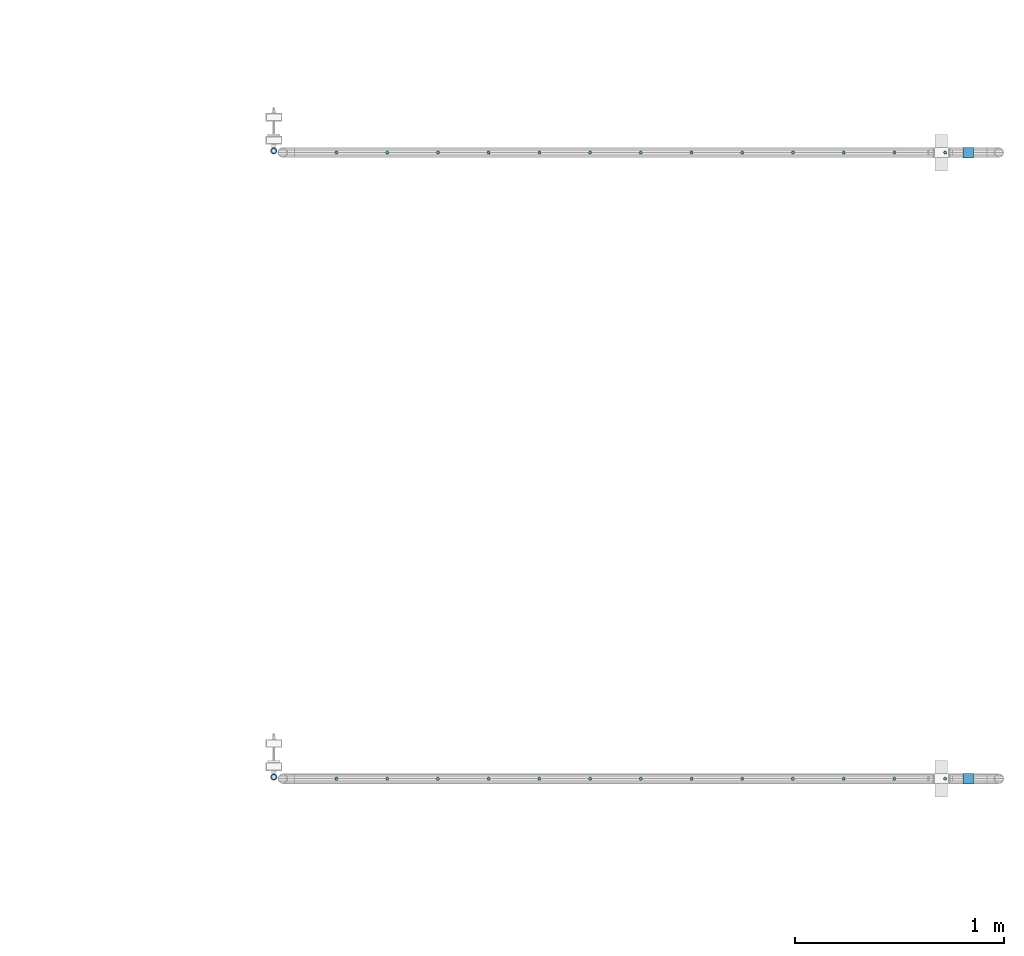
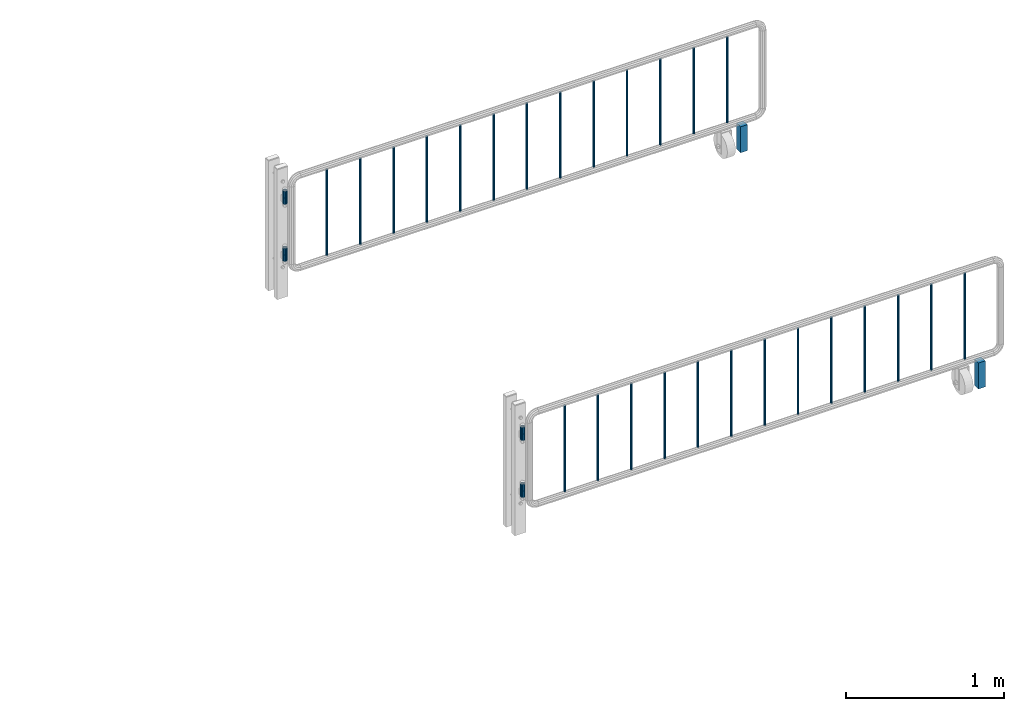
# One storey, part 89 of 208: 36 columns.
"""IFC2X3 building model written with IfcOpenShell, lengths in millimetres."""

from ifc_helpers import new_model, si_unit, frame, origin_with_axes, place, context, subcontext, project, spatial, faceted_brep, material, type_object, element, save


model = new_model("IFC2X3")

# Units and contexts
model_context = context("Model", 3, precision=1e-05, world=origin_with_axes())
body_context = subcontext(model_context, "Body", "Model", "MODEL_VIEW")
ifc_project = project(units=[si_unit("LENGTHUNIT", "METRE", prefix="MILLI"), si_unit("AREAUNIT", "SQUARE_METRE"), si_unit("VOLUMEUNIT", "CUBIC_METRE"), si_unit("MASSUNIT", "GRAM", prefix="KILO"), si_unit("TIMEUNIT", "SECOND"), si_unit("PLANEANGLEUNIT", "RADIAN"), si_unit("SOLIDANGLEUNIT", "STERADIAN"), si_unit("THERMODYNAMICTEMPERATUREUNIT", "DEGREE_CELSIUS"), si_unit("LUMINOUSINTENSITYUNIT", "LUMEN")], contexts=[model_context])

# Site, building, storey
site_placement = place(None, origin_with_axes())
site = spatial("IfcSite", under=ifc_project, at=site_placement, CompositionType="ELEMENT")
building_placement = place(site_placement, origin_with_axes())
building = spatial("IfcBuilding", under=site, at=building_placement, Name="Standard", CompositionType="ELEMENT")
storey_placement = place(building_placement, origin_with_axes())
storey = spatial("IfcBuildingStorey", under=building, at=storey_placement, Name="Undefined", CompositionType="ELEMENT", Elevation=0.0)

# Columns
ifc_material_1 = material(Name="STEEL/S355")
column_type_1 = type_object("IfcColumnType", PredefinedType="NOTDEFINED")
for number, where, z_axis, x_axis in (
    (1, (-12267.9037320793, 2941.85337247848, 0.500000000007276), (-1.0, 0.0, 0.0), (0.0, 0.0, 1.0)),
    (2, (-12267.9037320793, 5941.85337247848, 0.500000000007276), (-1.0, 0.0, 0.0), (0.0, 0.0, 1.0)),
):
    element("IfcColumn", number, at=place(storey_placement, frame(where, z_axis=z_axis, x_axis=x_axis)), inside=storey, type_object=column_type_1, material=ifc_material_1, context=body_context, shape_type="Brep", body=[
        faceted_brep([(0.0, 25.0, -25.0), (0.0, 25.0, 25.0), (200.0, 25.0, 25.0), (200.0, 25.0, -25.0), (0.0, -25.0, 25.0), (200.0, -25.0, 25.0), (0.0, -25.0, -25.0), (200.0, -25.0, -25.0)], [[[0, 1, 2, 3]], [[1, 4, 5, 2]], [[4, 6, 7, 5]], [[6, 0, 3, 7]], [[5, 7, 3, 2]], [[6, 4, 1, 0]]]),
    ])
ifc_material_2 = material()
column_type_2 = type_object("IfcColumnType", PredefinedType="NOTDEFINED")
column_1_placement = place(storey_placement, frame((-15594.2539762199, 2950.0039999962, 310.000000000008), z_axis=(-1.0, 0.0, 0.0), x_axis=(0.0, 0.0, 1.0)))
element("IfcColumn", 3, at=column_1_placement, inside=storey, type_object=column_type_2, material=ifc_material_2, context=body_context, shape_type="Brep", body=[
    faceted_brep([(0.0, -10.0, 0.0), (0.0, -8.66025403784442, 5.0), (50.0, -8.66025403784442, 5.0), (50.0, -10.0, 0.0), (0.0, -5.0, 8.66025403784442), (50.0, -5.0, 8.66025403784442), (0.0, 0.0, 10.0), (50.0, 0.0, 10.0), (0.0, 5.0, 8.66025403784442), (50.0, 5.0, 8.66025403784442), (0.0, 8.66025403784442, 5.0), (50.0, 8.66025403784442, 5.0), (0.0, 10.0, 0.0), (50.0, 10.0, 0.0), (0.0, 8.66025403784442, -5.0), (50.0, 8.66025403784442, -5.0), (0.0, 5.0, -8.66025403784442), (50.0, 5.0, -8.66025403784442), (0.0, 0.0, -10.0), (50.0, 0.0, -10.0), (0.0, -5.0, -8.66025403784442), (50.0, -5.0, -8.66025403784442), (0.0, -8.66025403784442, -5.0), (50.0, -8.66025403784442, -5.0), (0.0, -16.0, 0.0), (0.0, -13.8564064605512, -8.0), (50.0, -13.8564064605512, -8.0), (50.0, -16.0, 0.0), (0.0, -8.0, -13.8564064605507), (50.0, -8.0, -13.8564064605507), (0.0, 0.0, -16.0), (50.0, 0.0, -16.0), (0.0, 8.0, -13.8564064605507), (50.0, 8.0, -13.8564064605507), (0.0, 13.8564064605512, -8.0), (50.0, 13.8564064605512, -8.0), (0.0, 16.0, 0.0), (50.0, 16.0, 0.0), (0.0, 13.8564064605512, 8.0), (50.0, 13.8564064605512, 8.0), (0.0, 8.0, 13.8564064605507), (50.0, 8.0, 13.8564064605507), (0.0, 0.0, 16.0), (50.0, 0.0, 16.0), (0.0, -8.0, 13.8564064605507), (50.0, -8.0, 13.8564064605507), (0.0, -13.8564064605512, 8.0), (50.0, -13.8564064605512, 8.0)], [[[0, 1, 2, 3]], [[1, 4, 5, 2]], [[4, 6, 7, 5]], [[6, 8, 9, 7]], [[8, 10, 11, 9]], [[10, 12, 13, 11]], [[12, 14, 15, 13]], [[14, 16, 17, 15]], [[16, 18, 19, 17]], [[18, 20, 21, 19]], [[20, 22, 23, 21]], [[22, 0, 3, 23]], [[24, 25, 26, 27]], [[25, 28, 29, 26]], [[28, 30, 31, 29]], [[30, 32, 33, 31]], [[32, 34, 35, 33]], [[34, 36, 37, 35]], [[36, 38, 39, 37]], [[38, 40, 41, 39]], [[40, 42, 43, 41]], [[42, 44, 45, 43]], [[44, 46, 47, 45]], [[46, 24, 27, 47]], [[29, 31, 33, 35, 37, 39, 41, 43, 45, 47, 27, 26], [5, 7, 9, 11, 13, 15, 17, 19, 21, 23, 3, 2]], [[46, 44, 42, 40, 38, 36, 34, 32, 30, 28, 25, 24], [22, 20, 18, 16, 14, 12, 10, 8, 6, 4, 1, 0]]]),
])
column_2_placement = place(storey_placement, frame((-15594.2539762199, 2950.0039999962, 360.000000000008), z_axis=(-1.0, 0.0, 0.0), x_axis=(0.0, 0.0, 1.0)))
element("IfcColumn", 4, at=column_2_placement, inside=storey, type_object=column_type_2, material=ifc_material_2, context=body_context, shape_type="Brep", body=[
    faceted_brep([(0.0, -10.0, 0.0), (0.0, -8.66025403784442, 5.0), (50.0, -8.66025403784442, 5.0), (50.0, -10.0, 0.0), (0.0, -5.0, 8.66025403784442), (50.0, -5.0, 8.66025403784442), (0.0, 0.0, 10.0), (50.0, 0.0, 10.0), (0.0, 5.0, 8.66025403784442), (50.0, 5.0, 8.66025403784442), (0.0, 8.66025403784442, 5.0), (50.0, 8.66025403784442, 5.0), (0.0, 10.0, 0.0), (50.0, 10.0, 0.0), (0.0, 8.66025403784442, -5.0), (50.0, 8.66025403784442, -5.0), (0.0, 5.0, -8.66025403784442), (50.0, 5.0, -8.66025403784442), (0.0, 0.0, -10.0), (50.0, 0.0, -10.0), (0.0, -5.0, -8.66025403784442), (50.0, -5.0, -8.66025403784442), (0.0, -8.66025403784442, -5.0), (50.0, -8.66025403784442, -5.0), (0.0, -16.0, 0.0), (0.0, -13.8564064605512, -8.0), (50.0, -13.8564064605512, -8.0), (50.0, -16.0, 0.0), (0.0, -8.0, -13.8564064605507), (50.0, -8.0, -13.8564064605507), (0.0, 0.0, -16.0), (50.0, 0.0, -16.0), (0.0, 8.0, -13.8564064605507), (50.0, 8.0, -13.8564064605507), (0.0, 13.8564064605512, -8.0), (50.0, 13.8564064605512, -8.0), (0.0, 16.0, 0.0), (50.0, 16.0, 0.0), (0.0, 13.8564064605512, 8.0), (50.0, 13.8564064605512, 8.0), (0.0, 8.0, 13.8564064605507), (50.0, 8.0, 13.8564064605507), (0.0, 0.0, 16.0), (50.0, 0.0, 16.0), (0.0, -8.0, 13.8564064605507), (50.0, -8.0, 13.8564064605507), (0.0, -13.8564064605512, 8.0), (50.0, -13.8564064605512, 8.0)], [[[0, 1, 2, 3]], [[1, 4, 5, 2]], [[4, 6, 7, 5]], [[6, 8, 9, 7]], [[8, 10, 11, 9]], [[10, 12, 13, 11]], [[12, 14, 15, 13]], [[14, 16, 17, 15]], [[16, 18, 19, 17]], [[18, 20, 21, 19]], [[20, 22, 23, 21]], [[22, 0, 3, 23]], [[24, 25, 26, 27]], [[25, 28, 29, 26]], [[28, 30, 31, 29]], [[30, 32, 33, 31]], [[32, 34, 35, 33]], [[34, 36, 37, 35]], [[36, 38, 39, 37]], [[38, 40, 41, 39]], [[40, 42, 43, 41]], [[42, 44, 45, 43]], [[44, 46, 47, 45]], [[46, 24, 27, 47]], [[29, 31, 33, 35, 37, 39, 41, 43, 45, 47, 27, 26], [5, 7, 9, 11, 13, 15, 17, 19, 21, 23, 3, 2]], [[46, 44, 42, 40, 38, 36, 34, 32, 30, 28, 25, 24], [22, 20, 18, 16, 14, 12, 10, 8, 6, 4, 1, 0]]]),
])
column_3_placement = place(storey_placement, frame((-15594.2539762199, 2950.0039999962, 750.000000000008), z_axis=(-1.0, 0.0, 0.0), x_axis=(0.0, 0.0, 1.0)))
element("IfcColumn", 5, at=column_3_placement, inside=storey, type_object=column_type_2, material=ifc_material_2, context=body_context, shape_type="Brep", body=[
    faceted_brep([(0.0, -10.0, 0.0), (0.0, -8.66025403784442, 5.0), (50.0, -8.66025403784442, 5.0), (50.0, -10.0, 0.0), (0.0, -5.0, 8.66025403784442), (50.0, -5.0, 8.66025403784442), (0.0, 0.0, 10.0), (50.0, 0.0, 10.0), (0.0, 5.0, 8.66025403784442), (50.0, 5.0, 8.66025403784442), (0.0, 8.66025403784442, 5.0), (50.0, 8.66025403784442, 5.0), (0.0, 10.0, 0.0), (50.0, 10.0, 0.0), (0.0, 8.66025403784442, -5.0), (50.0, 8.66025403784442, -5.0), (0.0, 5.0, -8.66025403784442), (50.0, 5.0, -8.66025403784442), (0.0, 0.0, -10.0), (50.0, 0.0, -10.0), (0.0, -5.0, -8.66025403784442), (50.0, -5.0, -8.66025403784442), (0.0, -8.66025403784442, -5.0), (50.0, -8.66025403784442, -5.0), (0.0, -16.0, 0.0), (0.0, -13.8564064605512, -8.0), (50.0, -13.8564064605512, -8.0), (50.0, -16.0, 0.0), (0.0, -8.0, -13.8564064605507), (50.0, -8.0, -13.8564064605507), (0.0, 0.0, -16.0), (50.0, 0.0, -16.0), (0.0, 8.0, -13.8564064605507), (50.0, 8.0, -13.8564064605507), (0.0, 13.8564064605512, -8.0), (50.0, 13.8564064605512, -8.0), (0.0, 16.0, 0.0), (50.0, 16.0, 0.0), (0.0, 13.8564064605512, 8.0), (50.0, 13.8564064605512, 8.0), (0.0, 8.0, 13.8564064605507), (50.0, 8.0, 13.8564064605507), (0.0, 0.0, 16.0), (50.0, 0.0, 16.0), (0.0, -8.0, 13.8564064605507), (50.0, -8.0, 13.8564064605507), (0.0, -13.8564064605512, 8.0), (50.0, -13.8564064605512, 8.0)], [[[0, 1, 2, 3]], [[1, 4, 5, 2]], [[4, 6, 7, 5]], [[6, 8, 9, 7]], [[8, 10, 11, 9]], [[10, 12, 13, 11]], [[12, 14, 15, 13]], [[14, 16, 17, 15]], [[16, 18, 19, 17]], [[18, 20, 21, 19]], [[20, 22, 23, 21]], [[22, 0, 3, 23]], [[24, 25, 26, 27]], [[25, 28, 29, 26]], [[28, 30, 31, 29]], [[30, 32, 33, 31]], [[32, 34, 35, 33]], [[34, 36, 37, 35]], [[36, 38, 39, 37]], [[38, 40, 41, 39]], [[40, 42, 43, 41]], [[42, 44, 45, 43]], [[44, 46, 47, 45]], [[46, 24, 27, 47]], [[29, 31, 33, 35, 37, 39, 41, 43, 45, 47, 27, 26], [5, 7, 9, 11, 13, 15, 17, 19, 21, 23, 3, 2]], [[46, 44, 42, 40, 38, 36, 34, 32, 30, 28, 25, 24], [22, 20, 18, 16, 14, 12, 10, 8, 6, 4, 1, 0]]]),
])
column_4_placement = place(storey_placement, frame((-15594.2539762199, 2950.0039999962, 800.000000000008), z_axis=(-1.0, 0.0, 0.0), x_axis=(0.0, 0.0, 1.0)))
element("IfcColumn", 6, at=column_4_placement, inside=storey, type_object=column_type_2, material=ifc_material_2, context=body_context, shape_type="Brep", body=[
    faceted_brep([(0.0, -10.0, 0.0), (0.0, -8.66025403784442, 5.0), (50.0, -8.66025403784442, 5.0), (50.0, -10.0, 0.0), (0.0, -5.0, 8.66025403784442), (50.0, -5.0, 8.66025403784442), (0.0, 0.0, 10.0), (50.0, 0.0, 10.0), (0.0, 5.0, 8.66025403784442), (50.0, 5.0, 8.66025403784442), (0.0, 8.66025403784442, 5.0), (50.0, 8.66025403784442, 5.0), (0.0, 10.0, 0.0), (50.0, 10.0, 0.0), (0.0, 8.66025403784442, -5.0), (50.0, 8.66025403784442, -5.0), (0.0, 5.0, -8.66025403784442), (50.0, 5.0, -8.66025403784442), (0.0, 0.0, -10.0), (50.0, 0.0, -10.0), (0.0, -5.0, -8.66025403784442), (50.0, -5.0, -8.66025403784442), (0.0, -8.66025403784442, -5.0), (50.0, -8.66025403784442, -5.0), (0.0, -16.0, 0.0), (0.0, -13.8564064605512, -8.0), (50.0, -13.8564064605512, -8.0), (50.0, -16.0, 0.0), (0.0, -8.0, -13.8564064605507), (50.0, -8.0, -13.8564064605507), (0.0, 0.0, -16.0), (50.0, 0.0, -16.0), (0.0, 8.0, -13.8564064605507), (50.0, 8.0, -13.8564064605507), (0.0, 13.8564064605512, -8.0), (50.0, 13.8564064605512, -8.0), (0.0, 16.0, 0.0), (50.0, 16.0, 0.0), (0.0, 13.8564064605512, 8.0), (50.0, 13.8564064605512, 8.0), (0.0, 8.0, 13.8564064605507), (50.0, 8.0, 13.8564064605507), (0.0, 0.0, 16.0), (50.0, 0.0, 16.0), (0.0, -8.0, 13.8564064605507), (50.0, -8.0, 13.8564064605507), (0.0, -13.8564064605512, 8.0), (50.0, -13.8564064605512, 8.0)], [[[0, 1, 2, 3]], [[1, 4, 5, 2]], [[4, 6, 7, 5]], [[6, 8, 9, 7]], [[8, 10, 11, 9]], [[10, 12, 13, 11]], [[12, 14, 15, 13]], [[14, 16, 17, 15]], [[16, 18, 19, 17]], [[18, 20, 21, 19]], [[20, 22, 23, 21]], [[22, 0, 3, 23]], [[24, 25, 26, 27]], [[25, 28, 29, 26]], [[28, 30, 31, 29]], [[30, 32, 33, 31]], [[32, 34, 35, 33]], [[34, 36, 37, 35]], [[36, 38, 39, 37]], [[38, 40, 41, 39]], [[40, 42, 43, 41]], [[42, 44, 45, 43]], [[44, 46, 47, 45]], [[46, 24, 27, 47]], [[29, 31, 33, 35, 37, 39, 41, 43, 45, 47, 27, 26], [5, 7, 9, 11, 13, 15, 17, 19, 21, 23, 3, 2]], [[46, 44, 42, 40, 38, 36, 34, 32, 30, 28, 25, 24], [22, 20, 18, 16, 14, 12, 10, 8, 6, 4, 1, 0]]]),
])
column_5_placement = place(storey_placement, frame((-15594.2539762199, 5950.0039999962, 310.000000000008), z_axis=(-1.0, 0.0, 0.0), x_axis=(0.0, 0.0, 1.0)))
element("IfcColumn", 7, at=column_5_placement, inside=storey, type_object=column_type_2, material=ifc_material_2, context=body_context, shape_type="Brep", body=[
    faceted_brep([(0.0, -10.0, 0.0), (0.0, -8.66025403784442, 5.0), (50.0, -8.66025403784442, 5.0), (50.0, -10.0, 0.0), (0.0, -5.0, 8.66025403784442), (50.0, -5.0, 8.66025403784442), (0.0, 0.0, 10.0), (50.0, 0.0, 10.0), (0.0, 5.0, 8.66025403784442), (50.0, 5.0, 8.66025403784442), (0.0, 8.66025403784442, 5.0), (50.0, 8.66025403784442, 5.0), (0.0, 10.0, 0.0), (50.0, 10.0, 0.0), (0.0, 8.66025403784442, -5.0), (50.0, 8.66025403784442, -5.0), (0.0, 5.0, -8.66025403784442), (50.0, 5.0, -8.66025403784442), (0.0, 0.0, -10.0), (50.0, 0.0, -10.0), (0.0, -5.0, -8.66025403784442), (50.0, -5.0, -8.66025403784442), (0.0, -8.66025403784442, -5.0), (50.0, -8.66025403784442, -5.0), (0.0, -16.0, 0.0), (0.0, -13.8564064605512, -8.0), (50.0, -13.8564064605512, -8.0), (50.0, -16.0, 0.0), (0.0, -8.0, -13.8564064605507), (50.0, -8.0, -13.8564064605507), (0.0, 0.0, -16.0), (50.0, 0.0, -16.0), (0.0, 8.0, -13.8564064605507), (50.0, 8.0, -13.8564064605507), (0.0, 13.8564064605512, -8.0), (50.0, 13.8564064605512, -8.0), (0.0, 16.0, 0.0), (50.0, 16.0, 0.0), (0.0, 13.8564064605512, 8.0), (50.0, 13.8564064605512, 8.0), (0.0, 8.0, 13.8564064605507), (50.0, 8.0, 13.8564064605507), (0.0, 0.0, 16.0), (50.0, 0.0, 16.0), (0.0, -8.0, 13.8564064605507), (50.0, -8.0, 13.8564064605507), (0.0, -13.8564064605512, 8.0), (50.0, -13.8564064605512, 8.0)], [[[0, 1, 2, 3]], [[1, 4, 5, 2]], [[4, 6, 7, 5]], [[6, 8, 9, 7]], [[8, 10, 11, 9]], [[10, 12, 13, 11]], [[12, 14, 15, 13]], [[14, 16, 17, 15]], [[16, 18, 19, 17]], [[18, 20, 21, 19]], [[20, 22, 23, 21]], [[22, 0, 3, 23]], [[24, 25, 26, 27]], [[25, 28, 29, 26]], [[28, 30, 31, 29]], [[30, 32, 33, 31]], [[32, 34, 35, 33]], [[34, 36, 37, 35]], [[36, 38, 39, 37]], [[38, 40, 41, 39]], [[40, 42, 43, 41]], [[42, 44, 45, 43]], [[44, 46, 47, 45]], [[46, 24, 27, 47]], [[29, 31, 33, 35, 37, 39, 41, 43, 45, 47, 27, 26], [5, 7, 9, 11, 13, 15, 17, 19, 21, 23, 3, 2]], [[46, 44, 42, 40, 38, 36, 34, 32, 30, 28, 25, 24], [22, 20, 18, 16, 14, 12, 10, 8, 6, 4, 1, 0]]]),
])
column_6_placement = place(storey_placement, frame((-15594.2539762199, 5950.0039999962, 360.000000000008), z_axis=(-1.0, 0.0, 0.0), x_axis=(0.0, 0.0, 1.0)))
element("IfcColumn", 8, at=column_6_placement, inside=storey, type_object=column_type_2, material=ifc_material_2, context=body_context, shape_type="Brep", body=[
    faceted_brep([(0.0, -10.0, 0.0), (0.0, -8.66025403784442, 5.0), (50.0, -8.66025403784442, 5.0), (50.0, -10.0, 0.0), (0.0, -5.0, 8.66025403784442), (50.0, -5.0, 8.66025403784442), (0.0, 0.0, 10.0), (50.0, 0.0, 10.0), (0.0, 5.0, 8.66025403784442), (50.0, 5.0, 8.66025403784442), (0.0, 8.66025403784442, 5.0), (50.0, 8.66025403784442, 5.0), (0.0, 10.0, 0.0), (50.0, 10.0, 0.0), (0.0, 8.66025403784442, -5.0), (50.0, 8.66025403784442, -5.0), (0.0, 5.0, -8.66025403784442), (50.0, 5.0, -8.66025403784442), (0.0, 0.0, -10.0), (50.0, 0.0, -10.0), (0.0, -5.0, -8.66025403784442), (50.0, -5.0, -8.66025403784442), (0.0, -8.66025403784442, -5.0), (50.0, -8.66025403784442, -5.0), (0.0, -16.0, 0.0), (0.0, -13.8564064605512, -8.0), (50.0, -13.8564064605512, -8.0), (50.0, -16.0, 0.0), (0.0, -8.0, -13.8564064605507), (50.0, -8.0, -13.8564064605507), (0.0, 0.0, -16.0), (50.0, 0.0, -16.0), (0.0, 8.0, -13.8564064605507), (50.0, 8.0, -13.8564064605507), (0.0, 13.8564064605512, -8.0), (50.0, 13.8564064605512, -8.0), (0.0, 16.0, 0.0), (50.0, 16.0, 0.0), (0.0, 13.8564064605512, 8.0), (50.0, 13.8564064605512, 8.0), (0.0, 8.0, 13.8564064605507), (50.0, 8.0, 13.8564064605507), (0.0, 0.0, 16.0), (50.0, 0.0, 16.0), (0.0, -8.0, 13.8564064605507), (50.0, -8.0, 13.8564064605507), (0.0, -13.8564064605512, 8.0), (50.0, -13.8564064605512, 8.0)], [[[0, 1, 2, 3]], [[1, 4, 5, 2]], [[4, 6, 7, 5]], [[6, 8, 9, 7]], [[8, 10, 11, 9]], [[10, 12, 13, 11]], [[12, 14, 15, 13]], [[14, 16, 17, 15]], [[16, 18, 19, 17]], [[18, 20, 21, 19]], [[20, 22, 23, 21]], [[22, 0, 3, 23]], [[24, 25, 26, 27]], [[25, 28, 29, 26]], [[28, 30, 31, 29]], [[30, 32, 33, 31]], [[32, 34, 35, 33]], [[34, 36, 37, 35]], [[36, 38, 39, 37]], [[38, 40, 41, 39]], [[40, 42, 43, 41]], [[42, 44, 45, 43]], [[44, 46, 47, 45]], [[46, 24, 27, 47]], [[29, 31, 33, 35, 37, 39, 41, 43, 45, 47, 27, 26], [5, 7, 9, 11, 13, 15, 17, 19, 21, 23, 3, 2]], [[46, 44, 42, 40, 38, 36, 34, 32, 30, 28, 25, 24], [22, 20, 18, 16, 14, 12, 10, 8, 6, 4, 1, 0]]]),
])
column_7_placement = place(storey_placement, frame((-15594.2539762199, 5950.0039999962, 750.000000000008), z_axis=(-1.0, 0.0, 0.0), x_axis=(0.0, 0.0, 1.0)))
element("IfcColumn", 9, at=column_7_placement, inside=storey, type_object=column_type_2, material=ifc_material_2, context=body_context, shape_type="Brep", body=[
    faceted_brep([(0.0, -10.0, 0.0), (0.0, -8.66025403784442, 5.0), (50.0, -8.66025403784442, 5.0), (50.0, -10.0, 0.0), (0.0, -5.0, 8.66025403784442), (50.0, -5.0, 8.66025403784442), (0.0, 0.0, 10.0), (50.0, 0.0, 10.0), (0.0, 5.0, 8.66025403784442), (50.0, 5.0, 8.66025403784442), (0.0, 8.66025403784442, 5.0), (50.0, 8.66025403784442, 5.0), (0.0, 10.0, 0.0), (50.0, 10.0, 0.0), (0.0, 8.66025403784442, -5.0), (50.0, 8.66025403784442, -5.0), (0.0, 5.0, -8.66025403784442), (50.0, 5.0, -8.66025403784442), (0.0, 0.0, -10.0), (50.0, 0.0, -10.0), (0.0, -5.0, -8.66025403784442), (50.0, -5.0, -8.66025403784442), (0.0, -8.66025403784442, -5.0), (50.0, -8.66025403784442, -5.0), (0.0, -16.0, 0.0), (0.0, -13.8564064605512, -8.0), (50.0, -13.8564064605512, -8.0), (50.0, -16.0, 0.0), (0.0, -8.0, -13.8564064605507), (50.0, -8.0, -13.8564064605507), (0.0, 0.0, -16.0), (50.0, 0.0, -16.0), (0.0, 8.0, -13.8564064605507), (50.0, 8.0, -13.8564064605507), (0.0, 13.8564064605512, -8.0), (50.0, 13.8564064605512, -8.0), (0.0, 16.0, 0.0), (50.0, 16.0, 0.0), (0.0, 13.8564064605512, 8.0), (50.0, 13.8564064605512, 8.0), (0.0, 8.0, 13.8564064605507), (50.0, 8.0, 13.8564064605507), (0.0, 0.0, 16.0), (50.0, 0.0, 16.0), (0.0, -8.0, 13.8564064605507), (50.0, -8.0, 13.8564064605507), (0.0, -13.8564064605512, 8.0), (50.0, -13.8564064605512, 8.0)], [[[0, 1, 2, 3]], [[1, 4, 5, 2]], [[4, 6, 7, 5]], [[6, 8, 9, 7]], [[8, 10, 11, 9]], [[10, 12, 13, 11]], [[12, 14, 15, 13]], [[14, 16, 17, 15]], [[16, 18, 19, 17]], [[18, 20, 21, 19]], [[20, 22, 23, 21]], [[22, 0, 3, 23]], [[24, 25, 26, 27]], [[25, 28, 29, 26]], [[28, 30, 31, 29]], [[30, 32, 33, 31]], [[32, 34, 35, 33]], [[34, 36, 37, 35]], [[36, 38, 39, 37]], [[38, 40, 41, 39]], [[40, 42, 43, 41]], [[42, 44, 45, 43]], [[44, 46, 47, 45]], [[46, 24, 27, 47]], [[29, 31, 33, 35, 37, 39, 41, 43, 45, 47, 27, 26], [5, 7, 9, 11, 13, 15, 17, 19, 21, 23, 3, 2]], [[46, 44, 42, 40, 38, 36, 34, 32, 30, 28, 25, 24], [22, 20, 18, 16, 14, 12, 10, 8, 6, 4, 1, 0]]]),
])
column_8_placement = place(storey_placement, frame((-15594.2539762199, 5950.0039999962, 800.000000000008), z_axis=(-1.0, 0.0, 0.0), x_axis=(0.0, 0.0, 1.0)))
element("IfcColumn", 10, at=column_8_placement, inside=storey, type_object=column_type_2, material=ifc_material_2, context=body_context, shape_type="Brep", body=[
    faceted_brep([(0.0, -10.0, 0.0), (0.0, -8.66025403784442, 5.0), (50.0, -8.66025403784442, 5.0), (50.0, -10.0, 0.0), (0.0, -5.0, 8.66025403784442), (50.0, -5.0, 8.66025403784442), (0.0, 0.0, 10.0), (50.0, 0.0, 10.0), (0.0, 5.0, 8.66025403784442), (50.0, 5.0, 8.66025403784442), (0.0, 8.66025403784442, 5.0), (50.0, 8.66025403784442, 5.0), (0.0, 10.0, 0.0), (50.0, 10.0, 0.0), (0.0, 8.66025403784442, -5.0), (50.0, 8.66025403784442, -5.0), (0.0, 5.0, -8.66025403784442), (50.0, 5.0, -8.66025403784442), (0.0, 0.0, -10.0), (50.0, 0.0, -10.0), (0.0, -5.0, -8.66025403784442), (50.0, -5.0, -8.66025403784442), (0.0, -8.66025403784442, -5.0), (50.0, -8.66025403784442, -5.0), (0.0, -16.0, 0.0), (0.0, -13.8564064605512, -8.0), (50.0, -13.8564064605512, -8.0), (50.0, -16.0, 0.0), (0.0, -8.0, -13.8564064605507), (50.0, -8.0, -13.8564064605507), (0.0, 0.0, -16.0), (50.0, 0.0, -16.0), (0.0, 8.0, -13.8564064605507), (50.0, 8.0, -13.8564064605507), (0.0, 13.8564064605512, -8.0), (50.0, 13.8564064605512, -8.0), (0.0, 16.0, 0.0), (50.0, 16.0, 0.0), (0.0, 13.8564064605512, 8.0), (50.0, 13.8564064605512, 8.0), (0.0, 8.0, 13.8564064605507), (50.0, 8.0, 13.8564064605507), (0.0, 0.0, 16.0), (50.0, 0.0, 16.0), (0.0, -8.0, 13.8564064605507), (50.0, -8.0, 13.8564064605507), (0.0, -13.8564064605512, 8.0), (50.0, -13.8564064605512, 8.0)], [[[0, 1, 2, 3]], [[1, 4, 5, 2]], [[4, 6, 7, 5]], [[6, 8, 9, 7]], [[8, 10, 11, 9]], [[10, 12, 13, 11]], [[12, 14, 15, 13]], [[14, 16, 17, 15]], [[16, 18, 19, 17]], [[18, 20, 21, 19]], [[20, 22, 23, 21]], [[22, 0, 3, 23]], [[24, 25, 26, 27]], [[25, 28, 29, 26]], [[28, 30, 31, 29]], [[30, 32, 33, 31]], [[32, 34, 35, 33]], [[34, 36, 37, 35]], [[36, 38, 39, 37]], [[38, 40, 41, 39]], [[40, 42, 43, 41]], [[42, 44, 45, 43]], [[44, 46, 47, 45]], [[46, 24, 27, 47]], [[29, 31, 33, 35, 37, 39, 41, 43, 45, 47, 27, 26], [5, 7, 9, 11, 13, 15, 17, 19, 21, 23, 3, 2]], [[46, 44, 42, 40, 38, 36, 34, 32, 30, 28, 25, 24], [22, 20, 18, 16, 14, 12, 10, 8, 6, 4, 1, 0]]]),
])
ifc_material_3 = material(Name="STEEL/S355J2")
column_type_3 = type_object("IfcColumnType", Name="D16", PredefinedType="NOTDEFINED")
for number, where, z_axis, x_axis in (
    (11, (-15293.9039762199, 2941.85399999618, 248.800000000007), (-1.0, 0.0, 0.0), (0.0, 0.0, 1.0)),
    (12, (-15050.9039762199, 2941.85399999618, 248.800000000007), (-1.0, 0.0, 0.0), (0.0, 0.0, 1.0)),
    (13, (-14807.9039762199, 2941.85399999618, 248.800000000007), (-1.0, 0.0, 0.0), (0.0, 0.0, 1.0)),
    (14, (-14564.9039762199, 2941.85399999618, 248.800000000007), (-1.0, 0.0, 0.0), (0.0, 0.0, 1.0)),
    (15, (-14321.9039762199, 2941.85399999618, 248.800000000007), (-1.0, 0.0, 0.0), (0.0, 0.0, 1.0)),
    (16, (-14078.9039762199, 2941.85399999618, 248.800000000007), (-1.0, 0.0, 0.0), (0.0, 0.0, 1.0)),
    (17, (-13835.9039762199, 2941.85399999618, 248.800000000007), (-1.0, 0.0, 0.0), (0.0, 0.0, 1.0)),
    (18, (-13592.9039762199, 2941.85399999618, 248.800000000007), (-1.0, 0.0, 0.0), (0.0, 0.0, 1.0)),
    (19, (-13349.9039762199, 2941.85399999618, 248.800000000007), (-1.0, 0.0, 0.0), (0.0, 0.0, 1.0)),
    (20, (-13106.9039762199, 2941.85399999618, 248.800000000007), (-1.0, 0.0, 0.0), (0.0, 0.0, 1.0)),
    (21, (-12863.9039762199, 2941.85399999618, 248.800000000007), (-1.0, 0.0, 0.0), (0.0, 0.0, 1.0)),
    (22, (-12620.9039762199, 2941.85399999618, 248.800000000007), (-1.0, 0.0, 0.0), (0.0, 0.0, 1.0)),
    (23, (-12377.9039762199, 2941.85399999618, 248.800000000007), (-1.0, 0.0, 0.0), (0.0, 0.0, 1.0)),
    (24, (-15293.9039762199, 5941.85399999618, 248.800000000007), (-1.0, 0.0, 0.0), (0.0, 0.0, 1.0)),
    (25, (-15050.9039762199, 5941.85399999618, 248.800000000007), (-1.0, 0.0, 0.0), (0.0, 0.0, 1.0)),
    (26, (-14807.9039762199, 5941.85399999618, 248.800000000007), (-1.0, 0.0, 0.0), (0.0, 0.0, 1.0)),
    (27, (-14564.9039762199, 5941.85399999618, 248.800000000007), (-1.0, 0.0, 0.0), (0.0, 0.0, 1.0)),
    (28, (-14321.9039762199, 5941.85399999618, 248.800000000007), (-1.0, 0.0, 0.0), (0.0, 0.0, 1.0)),
    (29, (-14078.9039762199, 5941.85399999618, 248.800000000007), (-1.0, 0.0, 0.0), (0.0, 0.0, 1.0)),
    (30, (-13835.9039762199, 5941.85399999618, 248.800000000007), (-1.0, 0.0, 0.0), (0.0, 0.0, 1.0)),
    (31, (-13592.9039762199, 5941.85399999618, 248.800000000007), (-1.0, 0.0, 0.0), (0.0, 0.0, 1.0)),
    (32, (-13349.9039762199, 5941.85399999618, 248.800000000007), (-1.0, 0.0, 0.0), (0.0, 0.0, 1.0)),
    (33, (-13106.9039762199, 5941.85399999618, 248.800000000007), (-1.0, 0.0, 0.0), (0.0, 0.0, 1.0)),
    (34, (-12863.9039762199, 5941.85399999618, 248.800000000007), (-1.0, 0.0, 0.0), (0.0, 0.0, 1.0)),
    (35, (-12620.9039762199, 5941.85399999618, 248.800000000007), (-1.0, 0.0, 0.0), (0.0, 0.0, 1.0)),
    (36, (-12377.9039762199, 5941.85399999618, 248.800000000007), (-1.0, 0.0, 0.0), (0.0, 0.0, 1.0)),
):
    element("IfcColumn", number, at=place(storey_placement, frame(where, z_axis=z_axis, x_axis=x_axis)), inside=storey, type_object=column_type_3, material=ifc_material_3, ObjectType="D16", context=body_context, shape_type="Brep", body=[
        faceted_brep([(0.0, -8.0, 0.0), (0.0, -5.65685424949243, -5.65685424949152), (663.0, -5.65685424949243, -5.65685424949152), (663.0, -8.0, 0.0), (0.0, 0.0, -8.0), (663.0, 0.0, -8.0), (0.0, 5.65685424949243, -5.65685424949152), (663.0, 5.65685424949243, -5.65685424949152), (0.0, 8.0, 0.0), (663.0, 8.0, 0.0), (0.0, 5.65685424949243, 5.65685424949152), (663.0, 5.65685424949243, 5.65685424949152), (0.0, 0.0, 8.0), (663.0, 0.0, 8.0), (0.0, -5.65685424949243, 5.65685424949152), (663.0, -5.65685424949243, 5.65685424949152)], [[[0, 1, 2, 3]], [[1, 4, 5, 2]], [[4, 6, 7, 5]], [[6, 8, 9, 7]], [[8, 10, 11, 9]], [[10, 12, 13, 11]], [[12, 14, 15, 13]], [[14, 0, 3, 15]], [[5, 7, 9, 11, 13, 15, 3, 2]], [[14, 12, 10, 8, 6, 4, 1, 0]]]),
    ])

save(model, "model.ifc")
